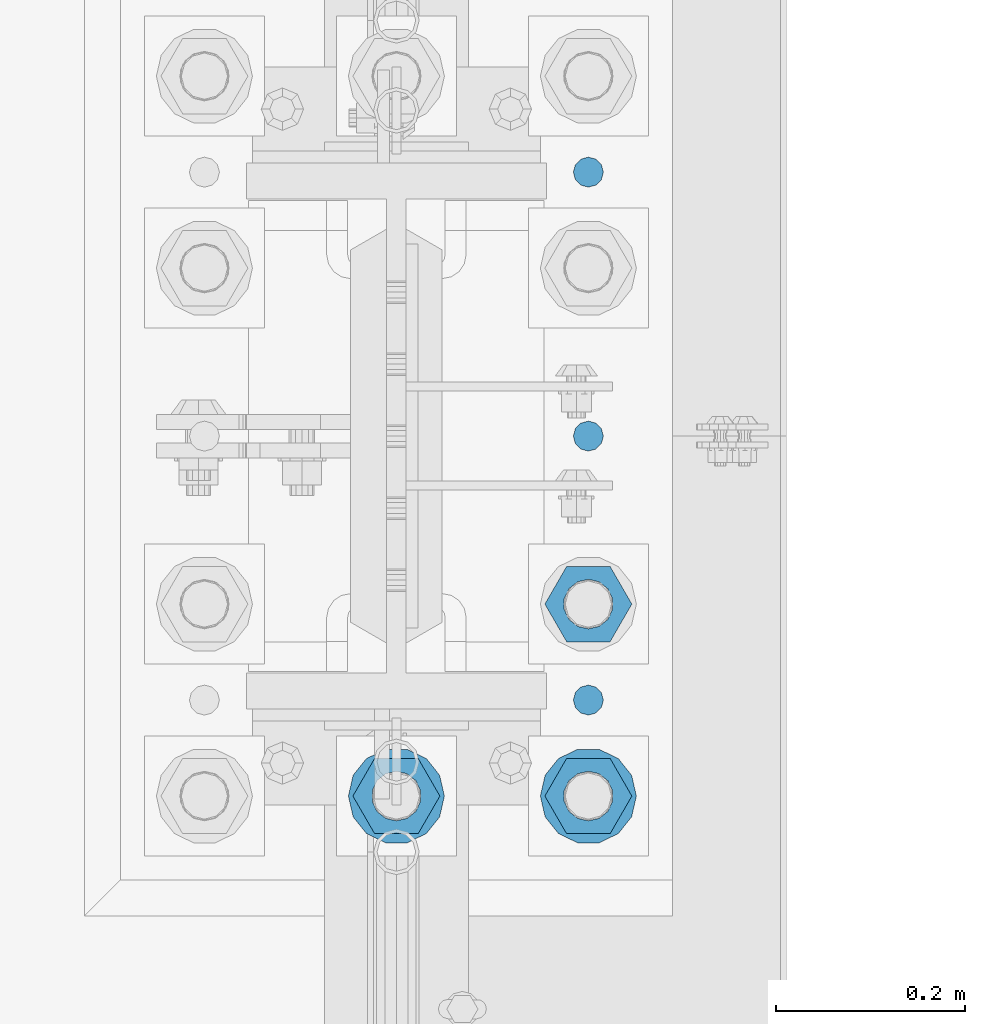
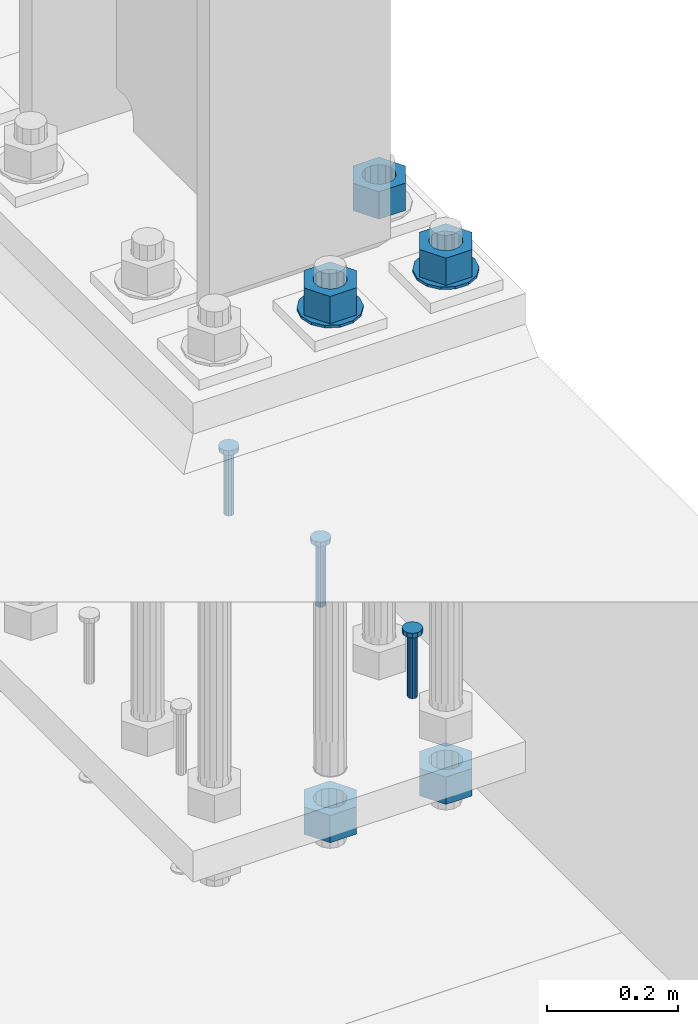
# One storey, part 842 of 1876: 10 columns, 1 element without a shape of its own.
"""IFC2X3 building model written with IfcOpenShell, lengths in millimetres."""

from ifc_helpers import new_model, si_unit, frame, origin_with_axes, place, context, subcontext, project, spatial, faceted_brep, material, type_object, element, aggregate, save


model = new_model("IFC2X3")

# Units and contexts
model_context = context("Model", 3, precision=1e-05, world=origin_with_axes())
body_context = subcontext(model_context, "Body", "Model", "MODEL_VIEW")
ifc_project = project(units=[si_unit("LENGTHUNIT", "METRE", prefix="MILLI"), si_unit("AREAUNIT", "SQUARE_METRE"), si_unit("VOLUMEUNIT", "CUBIC_METRE"), si_unit("MASSUNIT", "GRAM", prefix="KILO"), si_unit("TIMEUNIT", "SECOND"), si_unit("PLANEANGLEUNIT", "RADIAN"), si_unit("SOLIDANGLEUNIT", "STERADIAN"), si_unit("THERMODYNAMICTEMPERATUREUNIT", "DEGREE_CELSIUS"), si_unit("LUMINOUSINTENSITYUNIT", "LUMEN")], contexts=[model_context])

# Site, building, storey
site_placement = place(None, origin_with_axes())
site = spatial("IfcSite", under=ifc_project, at=site_placement, CompositionType="ELEMENT")
building_placement = place(site_placement, origin_with_axes())
building = spatial("IfcBuilding", under=site, at=building_placement, Name="Undefined", CompositionType="ELEMENT")
storey_placement = place(building_placement, origin_with_axes())
storey = spatial("IfcBuildingStorey", under=building, at=storey_placement, Name="Undefined", CompositionType="ELEMENT", Elevation=0.0)

# Assembly, columns
assembly_placement = place(storey_placement, origin_with_axes())
assembly = element("IfcElementAssembly", 1, at=assembly_placement, inside=storey, Name="TEMPLATE", AssemblyPlace="NOTDEFINED", PredefinedType="RIGID_FRAME")
ifc_material_1 = material(Name="STEEL/F436")
column_type_1 = type_object("IfcColumnType", Name="2_WASHER", PredefinedType="NOTDEFINED")
column_1_placement = place(assembly_placement, frame((7620.0, 1143.0, 119.0625), z_axis=(0.0, -1.0, 0.0), x_axis=(0.0, 0.0, -1.0)))
column_1 = element("IfcColumn", 2, at=column_1_placement, type_object=column_type_1, material=ifc_material_1, Name="WASHER", ObjectType="2_WASHER", context=body_context, shape_type="Brep", body=[
    faceted_brep([(0.0, -50.7999992370605, 9.09494701772928e-13), (0.0, -45.7692178020588, -22.0412936161442), (4.7625, -45.7692178020588, -22.0412936161442), (4.7625, -50.7999992370605, 9.09494701772928e-13), (0.0, -31.6732814587394, -39.7170387128856), (4.7625, -31.6732814587394, -39.7170387128856), (0.0, -11.3040632752118, -49.5263371950259), (4.7625, -11.3040632752118, -49.5263371950259), (0.0, 11.30406327521, -49.5263371950264), (4.7625, 11.30406327521, -49.5263371950264), (0.0, 31.6732814587385, -39.7170387128867), (4.7625, 31.6732814587385, -39.7170387128867), (0.0, 45.7692178020579, -22.041293616146), (4.7625, 45.7692178020579, -22.041293616146), (0.0, 50.7999992370605, -9.09494701772928e-13), (4.7625, 50.7999992370605, -9.09494701772928e-13), (0.0, 45.7692178020588, 22.0412936161442), (4.7625, 45.7692178020588, 22.0412936161442), (0.0, 31.6732814587394, 39.7170387128856), (4.7625, 31.6732814587394, 39.7170387128856), (0.0, 11.3040632752118, 49.5263371950259), (4.7625, 11.3040632752118, 49.5263371950259), (0.0, -11.30406327521, 49.5263371950264), (4.7625, -11.30406327521, 49.5263371950264), (0.0, -31.6732814587385, 39.7170387128867), (4.7625, -31.6732814587385, 39.7170387128867), (0.0, -45.7692178020579, 22.041293616146), (4.7625, -45.7692178020579, 22.041293616146), (0.0, 0.0, 26.9869995117188), (0.0, 11.7093983825444, 24.3146012721213), (4.7625, 11.7093983825444, 24.3146012721213), (4.7625, 0.0, 26.9869995117188), (0.0, 21.0996520289491, 16.8262864224157), (4.7625, 21.0996520289491, 16.8262864224157), (0.0, 26.3108629296712, 6.00524193584533), (4.7625, 26.3108629296712, 6.00524193584533), (0.0, 26.3108629296712, -6.00524193584533), (4.7625, 26.3108629296712, -6.00524193584533), (0.0, 21.0996520289491, -16.8262864224157), (4.7625, 21.0996520289491, -16.8262864224157), (0.0, 11.7093983825444, -24.3146012721213), (4.7625, 11.7093983825444, -24.3146012721213), (0.0, 0.0, -26.9869995117188), (4.7625, 0.0, -26.9869995117188), (0.0, -11.7093983825444, -24.3146012721213), (4.7625, -11.7093983825444, -24.3146012721213), (0.0, -21.0996520289491, -16.8262864224157), (4.7625, -21.0996520289491, -16.8262864224157), (0.0, -26.3108629296712, -6.00524193584533), (4.7625, -26.3108629296712, -6.00524193584533), (0.0, -26.3108629296712, 6.00524193584533), (4.7625, -26.3108629296712, 6.00524193584533), (0.0, -21.0996520289491, 16.8262864224157), (4.7625, -21.0996520289491, 16.8262864224157), (0.0, -11.7093983825444, 24.3146012721213), (4.7625, -11.7093983825444, 24.3146012721213)], [[[0, 1, 2, 3]], [[1, 4, 5, 2]], [[4, 6, 7, 5]], [[6, 8, 9, 7]], [[8, 10, 11, 9]], [[10, 12, 13, 11]], [[12, 14, 15, 13]], [[14, 16, 17, 15]], [[16, 18, 19, 17]], [[18, 20, 21, 19]], [[20, 22, 23, 21]], [[22, 24, 25, 23]], [[24, 26, 27, 25]], [[26, 0, 3, 27]], [[28, 29, 30, 31]], [[29, 32, 33, 30]], [[32, 34, 35, 33]], [[34, 36, 37, 35]], [[36, 38, 39, 37]], [[38, 40, 41, 39]], [[40, 42, 43, 41]], [[42, 44, 45, 43]], [[44, 46, 47, 45]], [[46, 48, 49, 47]], [[48, 50, 51, 49]], [[50, 52, 53, 51]], [[52, 54, 55, 53]], [[54, 28, 31, 55]], [[5, 7, 9, 11, 13, 15, 17, 19, 21, 23, 25, 27, 3, 2], [33, 35, 37, 39, 41, 43, 45, 47, 49, 51, 53, 55, 31, 30]], [[26, 24, 22, 20, 18, 16, 14, 12, 10, 8, 6, 4, 1, 0], [54, 52, 50, 48, 46, 44, 42, 40, 38, 36, 34, 32, 29, 28]]]),
])
column_2_placement = place(assembly_placement, frame((7823.2, 1143.0, 119.0625), z_axis=(0.0, 1.0, 0.0), x_axis=(0.0, 0.0, -1.0)))
column_2 = element("IfcColumn", 3, at=column_2_placement, type_object=column_type_1, material=ifc_material_1, Name="WASHER", ObjectType="2_WASHER", context=body_context, shape_type="Brep", body=[
    faceted_brep([(0.0, -50.7999992370605, 9.09494701772928e-13), (0.0, -45.7692178020588, -22.0412936161442), (4.7625, -45.7692178020588, -22.0412936161442), (4.7625, -50.7999992370605, 9.09494701772928e-13), (0.0, -31.6732814587394, -39.7170387128856), (4.7625, -31.6732814587394, -39.7170387128856), (0.0, -11.3040632752118, -49.5263371950259), (4.7625, -11.3040632752118, -49.5263371950259), (0.0, 11.30406327521, -49.5263371950264), (4.7625, 11.30406327521, -49.5263371950264), (0.0, 31.6732814587385, -39.7170387128867), (4.7625, 31.6732814587385, -39.7170387128867), (0.0, 45.7692178020579, -22.041293616146), (4.7625, 45.7692178020579, -22.041293616146), (0.0, 50.7999992370605, -9.09494701772928e-13), (4.7625, 50.7999992370605, -9.09494701772928e-13), (0.0, 45.7692178020588, 22.0412936161442), (4.7625, 45.7692178020588, 22.0412936161442), (0.0, 31.6732814587394, 39.7170387128856), (4.7625, 31.6732814587394, 39.7170387128856), (0.0, 11.3040632752118, 49.5263371950259), (4.7625, 11.3040632752118, 49.5263371950259), (0.0, -11.30406327521, 49.5263371950264), (4.7625, -11.30406327521, 49.5263371950264), (0.0, -31.6732814587385, 39.7170387128867), (4.7625, -31.6732814587385, 39.7170387128867), (0.0, -45.7692178020579, 22.041293616146), (4.7625, -45.7692178020579, 22.041293616146), (0.0, 0.0, 26.9869995117188), (0.0, 11.7093983825444, 24.3146012721213), (4.7625, 11.7093983825444, 24.3146012721213), (4.7625, 0.0, 26.9869995117188), (0.0, 21.0996520289491, 16.8262864224157), (4.7625, 21.0996520289491, 16.8262864224157), (0.0, 26.3108629296712, 6.00524193584533), (4.7625, 26.3108629296712, 6.00524193584533), (0.0, 26.3108629296712, -6.00524193584533), (4.7625, 26.3108629296712, -6.00524193584533), (0.0, 21.0996520289491, -16.8262864224157), (4.7625, 21.0996520289491, -16.8262864224157), (0.0, 11.7093983825444, -24.3146012721213), (4.7625, 11.7093983825444, -24.3146012721213), (0.0, 0.0, -26.9869995117188), (4.7625, 0.0, -26.9869995117188), (0.0, -11.7093983825444, -24.3146012721213), (4.7625, -11.7093983825444, -24.3146012721213), (0.0, -21.0996520289491, -16.8262864224157), (4.7625, -21.0996520289491, -16.8262864224157), (0.0, -26.3108629296712, -6.00524193584533), (4.7625, -26.3108629296712, -6.00524193584533), (0.0, -26.3108629296712, 6.00524193584533), (4.7625, -26.3108629296712, 6.00524193584533), (0.0, -21.0996520289491, 16.8262864224157), (4.7625, -21.0996520289491, 16.8262864224157), (0.0, -11.7093983825444, 24.3146012721213), (4.7625, -11.7093983825444, 24.3146012721213)], [[[0, 1, 2, 3]], [[1, 4, 5, 2]], [[4, 6, 7, 5]], [[6, 8, 9, 7]], [[8, 10, 11, 9]], [[10, 12, 13, 11]], [[12, 14, 15, 13]], [[14, 16, 17, 15]], [[16, 18, 19, 17]], [[18, 20, 21, 19]], [[20, 22, 23, 21]], [[22, 24, 25, 23]], [[24, 26, 27, 25]], [[26, 0, 3, 27]], [[28, 29, 30, 31]], [[29, 32, 33, 30]], [[32, 34, 35, 33]], [[34, 36, 37, 35]], [[36, 38, 39, 37]], [[38, 40, 41, 39]], [[40, 42, 43, 41]], [[42, 44, 45, 43]], [[44, 46, 47, 45]], [[46, 48, 49, 47]], [[48, 50, 51, 49]], [[50, 52, 53, 51]], [[52, 54, 55, 53]], [[54, 28, 31, 55]], [[5, 7, 9, 11, 13, 15, 17, 19, 21, 23, 25, 27, 3, 2], [33, 35, 37, 39, 41, 43, 45, 47, 49, 51, 53, 55, 31, 30]], [[26, 24, 22, 20, 18, 16, 14, 12, 10, 8, 6, 4, 1, 0], [54, 52, 50, 48, 46, 44, 42, 40, 38, 36, 34, 32, 29, 28]]]),
])
ifc_material_2 = material(Name="STEEL/A108")
column_type_2 = type_object("IfcColumnType", Name="5/8-DIA_HEADED ANCHOR STUD", PredefinedType="NOTDEFINED")
column_3_placement = place(assembly_placement, frame((7823.2, 1803.4, -736.6), z_axis=(1.0, 0.0, 0.0), x_axis=(0.0, 0.0, 1.0)))
column_3 = element("IfcColumn", 4, at=column_3_placement, type_object=column_type_2, material=ifc_material_2, Name="HEADED ANCHOR STUD", ObjectType="5/8-DIA_HEADED ANCHOR STUD", context=body_context, shape_type="Brep", body=[
    faceted_brep([(0.0, -7.94000005722046, 0.0), (0.0, -6.86999988555908, -3.97000002861023), (116.84, -6.86999988555908, -3.97000002861023), (116.84, -7.94000005722046, 0.0), (0.0, -3.97000002861023, -6.86999988555908), (116.84, -3.97000002861023, -6.86999988555908), (0.0, 0.0, -7.94000005722046), (116.84, 0.0, -7.94000005722046), (0.0, 3.97000002861023, -6.86999988555908), (116.84, 3.97000002861023, -6.86999988555908), (0.0, 6.86999988555908, -3.97000002861023), (116.84, 6.86999988555908, -3.97000002861023), (0.0, 7.94000005722046, 0.0), (116.84, 7.94000005722046, 0.0), (0.0, 6.86999988555908, 3.97000002861023), (116.84, 6.86999988555908, 3.97000002861023), (0.0, 3.97000002861023, 6.86999988555908), (116.84, 3.97000002861023, 6.86999988555908), (0.0, 0.0, 7.94000005722046), (116.84, 0.0, 7.94000005722046), (0.0, -3.97000002861023, 6.86999988555908), (116.84, -3.97000002861023, 6.86999988555908), (0.0, -6.86999988555908, 3.97000002861023), (116.84, -6.86999988555908, 3.97000002861023), (118.11, -13.75, -7.94000005722046), (118.11, -15.8800001144409, 0.0), (118.11, -7.94000005722046, -13.75), (118.11, 0.0, -15.8800001144409), (118.11, 7.94000005722046, -13.75), (118.11, 13.75, -7.94000005722046), (118.11, 15.8800001144409, 0.0), (118.11, 13.75, 7.94000005722046), (118.11, 7.94000005722046, 13.75), (118.11, 0.0, 15.8800001144409), (118.11, -7.94000005722046, 13.75), (118.11, -13.75, 7.94000005722046), (127.0, -13.75, -7.94000005722046), (127.0, -15.8800001144409, 0.0), (127.0, -7.94000005722046, -13.75), (127.0, 0.0, -15.8800001144409), (127.0, 7.94000005722046, -13.75), (127.0, 13.75, -7.94000005722046), (127.0, 15.8800001144409, 0.0), (127.0, 13.75, 7.94000005722046), (127.0, 7.94000005722046, 13.75), (127.0, 0.0, 15.8800001144409), (127.0, -7.94000005722046, 13.75), (127.0, -13.75, 7.94000005722046)], [[[0, 1, 2, 3]], [[1, 4, 5, 2]], [[4, 6, 7, 5]], [[6, 8, 9, 7]], [[8, 10, 11, 9]], [[10, 12, 13, 11]], [[12, 14, 15, 13]], [[14, 16, 17, 15]], [[16, 18, 19, 17]], [[18, 20, 21, 19]], [[20, 22, 23, 21]], [[22, 0, 3, 23]], [[22, 20, 18, 16, 14, 12, 10, 8, 6, 4, 1, 0]], [[3, 2, 24, 25]], [[2, 5, 26, 24]], [[5, 7, 27, 26]], [[7, 9, 28, 27]], [[9, 11, 29, 28]], [[11, 13, 30, 29]], [[13, 15, 31, 30]], [[15, 17, 32, 31]], [[17, 19, 33, 32]], [[19, 21, 34, 33]], [[21, 23, 35, 34]], [[23, 3, 25, 35]], [[25, 24, 36, 37]], [[24, 26, 38, 36]], [[26, 27, 39, 38]], [[27, 28, 40, 39]], [[28, 29, 41, 40]], [[29, 30, 42, 41]], [[30, 31, 43, 42]], [[31, 32, 44, 43]], [[32, 33, 45, 44]], [[33, 34, 46, 45]], [[34, 35, 47, 46]], [[35, 25, 37, 47]], [[38, 39, 40, 41, 42, 43, 44, 45, 46, 47, 37, 36]]]),
])
column_4_placement = place(assembly_placement, frame((7823.2, 1244.6, -736.6), z_axis=(1.0, 0.0, 0.0), x_axis=(0.0, 0.0, 1.0)))
column_4 = element("IfcColumn", 5, at=column_4_placement, type_object=column_type_2, material=ifc_material_2, Name="HEADED ANCHOR STUD", ObjectType="5/8-DIA_HEADED ANCHOR STUD", context=body_context, shape_type="Brep", body=[
    faceted_brep([(0.0, -7.94000005722046, 0.0), (0.0, -6.86999988555908, -3.97000002861023), (116.84, -6.86999988555908, -3.97000002861023), (116.84, -7.94000005722046, 0.0), (0.0, -3.97000002861023, -6.86999988555908), (116.84, -3.97000002861023, -6.86999988555908), (0.0, 0.0, -7.94000005722046), (116.84, 0.0, -7.94000005722046), (0.0, 3.97000002861023, -6.86999988555908), (116.84, 3.97000002861023, -6.86999988555908), (0.0, 6.86999988555908, -3.97000002861023), (116.84, 6.86999988555908, -3.97000002861023), (0.0, 7.94000005722046, 0.0), (116.84, 7.94000005722046, 0.0), (0.0, 6.86999988555908, 3.97000002861023), (116.84, 6.86999988555908, 3.97000002861023), (0.0, 3.97000002861023, 6.86999988555908), (116.84, 3.97000002861023, 6.86999988555908), (0.0, 0.0, 7.94000005722046), (116.84, 0.0, 7.94000005722046), (0.0, -3.97000002861023, 6.86999988555908), (116.84, -3.97000002861023, 6.86999988555908), (0.0, -6.86999988555908, 3.97000002861023), (116.84, -6.86999988555908, 3.97000002861023), (118.11, -13.75, -7.94000005722046), (118.11, -15.8800001144409, 0.0), (118.11, -7.94000005722046, -13.75), (118.11, 0.0, -15.8800001144409), (118.11, 7.94000005722046, -13.75), (118.11, 13.75, -7.94000005722046), (118.11, 15.8800001144409, 0.0), (118.11, 13.75, 7.94000005722046), (118.11, 7.94000005722046, 13.75), (118.11, 0.0, 15.8800001144409), (118.11, -7.94000005722046, 13.75), (118.11, -13.75, 7.94000005722046), (127.0, -13.75, -7.94000005722046), (127.0, -15.8800001144409, 0.0), (127.0, -7.94000005722046, -13.75), (127.0, 0.0, -15.8800001144409), (127.0, 7.94000005722046, -13.75), (127.0, 13.75, -7.94000005722046), (127.0, 15.8800001144409, 0.0), (127.0, 13.75, 7.94000005722046), (127.0, 7.94000005722046, 13.75), (127.0, 0.0, 15.8800001144409), (127.0, -7.94000005722046, 13.75), (127.0, -13.75, 7.94000005722046)], [[[0, 1, 2, 3]], [[1, 4, 5, 2]], [[4, 6, 7, 5]], [[6, 8, 9, 7]], [[8, 10, 11, 9]], [[10, 12, 13, 11]], [[12, 14, 15, 13]], [[14, 16, 17, 15]], [[16, 18, 19, 17]], [[18, 20, 21, 19]], [[20, 22, 23, 21]], [[22, 0, 3, 23]], [[22, 20, 18, 16, 14, 12, 10, 8, 6, 4, 1, 0]], [[3, 2, 24, 25]], [[2, 5, 26, 24]], [[5, 7, 27, 26]], [[7, 9, 28, 27]], [[9, 11, 29, 28]], [[11, 13, 30, 29]], [[13, 15, 31, 30]], [[15, 17, 32, 31]], [[17, 19, 33, 32]], [[19, 21, 34, 33]], [[21, 23, 35, 34]], [[23, 3, 25, 35]], [[25, 24, 36, 37]], [[24, 26, 38, 36]], [[26, 27, 39, 38]], [[27, 28, 40, 39]], [[28, 29, 41, 40]], [[29, 30, 42, 41]], [[30, 31, 43, 42]], [[31, 32, 44, 43]], [[32, 33, 45, 44]], [[33, 34, 46, 45]], [[34, 35, 47, 46]], [[35, 25, 37, 47]], [[38, 39, 40, 41, 42, 43, 44, 45, 46, 47, 37, 36]]]),
])
column_5_placement = place(assembly_placement, frame((7823.2, 1524.0, -736.6), z_axis=(1.0, 0.0, 0.0), x_axis=(0.0, 0.0, 1.0)))
column_5 = element("IfcColumn", 6, at=column_5_placement, type_object=column_type_2, material=ifc_material_2, Name="HEADED ANCHOR STUD", ObjectType="5/8-DIA_HEADED ANCHOR STUD", context=body_context, shape_type="Brep", body=[
    faceted_brep([(0.0, -7.94000005722046, 0.0), (0.0, -6.86999988555908, -3.97000002861023), (116.84, -6.86999988555908, -3.97000002861023), (116.84, -7.94000005722046, 0.0), (0.0, -3.97000002861023, -6.86999988555908), (116.84, -3.97000002861023, -6.86999988555908), (0.0, 0.0, -7.94000005722046), (116.84, 0.0, -7.94000005722046), (0.0, 3.97000002861023, -6.86999988555908), (116.84, 3.97000002861023, -6.86999988555908), (0.0, 6.86999988555908, -3.97000002861023), (116.84, 6.86999988555908, -3.97000002861023), (0.0, 7.94000005722046, 0.0), (116.84, 7.94000005722046, 0.0), (0.0, 6.86999988555908, 3.97000002861023), (116.84, 6.86999988555908, 3.97000002861023), (0.0, 3.97000002861023, 6.86999988555908), (116.84, 3.97000002861023, 6.86999988555908), (0.0, 0.0, 7.94000005722046), (116.84, 0.0, 7.94000005722046), (0.0, -3.97000002861023, 6.86999988555908), (116.84, -3.97000002861023, 6.86999988555908), (0.0, -6.86999988555908, 3.97000002861023), (116.84, -6.86999988555908, 3.97000002861023), (118.11, -13.75, -7.94000005722046), (118.11, -15.8800001144409, 0.0), (118.11, -7.94000005722046, -13.75), (118.11, 0.0, -15.8800001144409), (118.11, 7.94000005722046, -13.75), (118.11, 13.75, -7.94000005722046), (118.11, 15.8800001144409, 0.0), (118.11, 13.75, 7.94000005722046), (118.11, 7.94000005722046, 13.75), (118.11, 0.0, 15.8800001144409), (118.11, -7.94000005722046, 13.75), (118.11, -13.75, 7.94000005722046), (127.0, -13.75, -7.94000005722046), (127.0, -15.8800001144409, 0.0), (127.0, -7.94000005722046, -13.75), (127.0, 0.0, -15.8800001144409), (127.0, 7.94000005722046, -13.75), (127.0, 13.75, -7.94000005722046), (127.0, 15.8800001144409, 0.0), (127.0, 13.75, 7.94000005722046), (127.0, 7.94000005722046, 13.75), (127.0, 0.0, 15.8800001144409), (127.0, -7.94000005722046, 13.75), (127.0, -13.75, 7.94000005722046)], [[[0, 1, 2, 3]], [[1, 4, 5, 2]], [[4, 6, 7, 5]], [[6, 8, 9, 7]], [[8, 10, 11, 9]], [[10, 12, 13, 11]], [[12, 14, 15, 13]], [[14, 16, 17, 15]], [[16, 18, 19, 17]], [[18, 20, 21, 19]], [[20, 22, 23, 21]], [[22, 0, 3, 23]], [[22, 20, 18, 16, 14, 12, 10, 8, 6, 4, 1, 0]], [[3, 2, 24, 25]], [[2, 5, 26, 24]], [[5, 7, 27, 26]], [[7, 9, 28, 27]], [[9, 11, 29, 28]], [[11, 13, 30, 29]], [[13, 15, 31, 30]], [[15, 17, 32, 31]], [[17, 19, 33, 32]], [[19, 21, 34, 33]], [[21, 23, 35, 34]], [[23, 3, 25, 35]], [[25, 24, 36, 37]], [[24, 26, 38, 36]], [[26, 27, 39, 38]], [[27, 28, 40, 39]], [[28, 29, 41, 40]], [[29, 30, 42, 41]], [[30, 31, 43, 42]], [[31, 32, 44, 43]], [[32, 33, 45, 44]], [[33, 34, 46, 45]], [[34, 35, 47, 46]], [[35, 25, 37, 47]], [[38, 39, 40, 41, 42, 43, 44, 45, 46, 47, 37, 36]]]),
])
ifc_material_3 = material(Name="STEEL/A563")
column_type_3 = type_object("IfcColumnType", Name="2_HEAVY_HEX_NUT", PredefinedType="NOTDEFINED")
column_6_placement = place(assembly_placement, frame((7620.0, 1143.0, 169.8625), z_axis=(0.0, -1.0, 0.0), x_axis=(0.0, 0.0, -1.0)))
column_6 = element("IfcColumn", 7, at=column_6_placement, type_object=column_type_3, material=ifc_material_3, Name="NUT", ObjectType="2_HEAVY_HEX_NUT", context=body_context, shape_type="Brep", body=[
    faceted_brep([(0.0, -46.0369987487793, 9.09494701772928e-13), (0.0, -23.0184993743896, -39.869213104248), (50.8, -23.0184993743896, -39.869213104248), (50.8, -46.0369987487793, 9.09494701772928e-13), (0.0, 23.0184993743896, -39.869213104248), (50.8, 23.0184993743896, -39.869213104248), (0.0, 46.0369987487793, -9.09494701772928e-13), (50.8, 46.0369987487793, -9.09494701772928e-13), (0.0, 23.0184993743896, 39.869213104248), (50.8, 23.0184993743896, 39.869213104248), (0.0, -23.0184993743896, 39.869213104248), (50.8, -23.0184993743896, 39.869213104248), (0.0, 0.0, 26.1940002441406), (0.0, 11.3650617044514, 23.5999013092769), (50.8, 11.3650617044513, 23.5999013092771), (50.8, 0.0, 26.1940002441406), (0.0, 20.4791109456437, 16.3316083006703), (50.8, 20.4791109456439, 16.3316083006703), (0.0, 25.5370200498346, 5.82867859874477), (50.8, 25.5370200498343, 5.82867859874455), (0.0, 25.5370200498346, -5.82867859874477), (50.8, 25.5370200498343, -5.82867859874455), (0.0, 20.4791109456437, -16.3316083006703), (50.8, 20.4791109456439, -16.3316083006703), (0.0, 11.3650617044514, -23.5999013092769), (50.8, 11.3650617044514, -23.5999013092771), (0.0, 0.0, -26.1940002441406), (50.8, 0.0, -26.1940002441406), (0.0, -11.3650617044514, -23.5999013092769), (50.8, -11.3650617044513, -23.5999013092771), (0.0, -20.4791109456437, -16.3316083006703), (50.8, -20.4791109456439, -16.3316083006703), (0.0, -25.5370200498346, -5.82867859874477), (50.8, -25.5370200498343, -5.82867859874455), (0.0, -25.5370200498346, 5.82867859874477), (50.8, -25.5370200498343, 5.82867859874455), (0.0, -20.4791109456437, 16.3316083006703), (50.8, -20.4791109456439, 16.3316083006703), (0.0, -11.3650617044514, 23.5999013092769), (50.8, -11.3650617044514, 23.5999013092771)], [[[0, 1, 2, 3]], [[1, 4, 5, 2]], [[4, 6, 7, 5]], [[6, 8, 9, 7]], [[8, 10, 11, 9]], [[10, 0, 3, 11]], [[12, 13, 14, 15]], [[13, 16, 17, 14]], [[16, 18, 19, 17]], [[18, 20, 21, 19]], [[20, 22, 23, 21]], [[22, 24, 25, 23]], [[24, 26, 27, 25]], [[26, 28, 29, 27]], [[28, 30, 31, 29]], [[30, 32, 33, 31]], [[32, 34, 35, 33]], [[34, 36, 37, 35]], [[36, 38, 39, 37]], [[38, 12, 15, 39]], [[5, 7, 9, 11, 3, 2], [17, 19, 21, 23, 25, 27, 29, 31, 33, 35, 37, 39, 15, 14]], [[10, 8, 6, 4, 1, 0], [38, 36, 34, 32, 30, 28, 26, 24, 22, 20, 18, 16, 13, 12]]]),
])
column_7_placement = place(assembly_placement, frame((7620.0, 1143.0, -793.75), z_axis=(0.0, -1.0, 0.0), x_axis=(0.0, 0.0, -1.0)))
column_7 = element("IfcColumn", 8, at=column_7_placement, type_object=column_type_3, material=ifc_material_3, Name="NUT", ObjectType="2_HEAVY_HEX_NUT", context=body_context, shape_type="Brep", body=[
    faceted_brep([(0.0, -46.0369987487793, 9.09494701772928e-13), (0.0, -23.0184993743896, -39.869213104248), (50.8, -23.0184993743896, -39.869213104248), (50.8, -46.0369987487793, 9.09494701772928e-13), (0.0, 23.0184993743896, -39.869213104248), (50.8, 23.0184993743896, -39.869213104248), (0.0, 46.0369987487793, -9.09494701772928e-13), (50.8, 46.0369987487793, -9.09494701772928e-13), (0.0, 23.0184993743896, 39.869213104248), (50.8, 23.0184993743896, 39.869213104248), (0.0, -23.0184993743896, 39.869213104248), (50.8, -23.0184993743896, 39.869213104248), (0.0, 0.0, 26.1940002441406), (0.0, 11.3650617044514, 23.5999013092769), (50.8, 11.3650617044513, 23.5999013092771), (50.8, 0.0, 26.1940002441406), (0.0, 20.4791109456437, 16.3316083006703), (50.8, 20.4791109456439, 16.3316083006703), (0.0, 25.5370200498346, 5.82867859874477), (50.8, 25.5370200498343, 5.82867859874455), (0.0, 25.5370200498346, -5.82867859874477), (50.8, 25.5370200498343, -5.82867859874455), (0.0, 20.4791109456437, -16.3316083006703), (50.8, 20.4791109456439, -16.3316083006703), (0.0, 11.3650617044514, -23.5999013092769), (50.8, 11.3650617044514, -23.5999013092771), (0.0, 0.0, -26.1940002441406), (50.8, 0.0, -26.1940002441406), (0.0, -11.3650617044514, -23.5999013092769), (50.8, -11.3650617044513, -23.5999013092771), (0.0, -20.4791109456437, -16.3316083006703), (50.8, -20.4791109456439, -16.3316083006703), (0.0, -25.5370200498346, -5.82867859874477), (50.8, -25.5370200498343, -5.82867859874455), (0.0, -25.5370200498346, 5.82867859874477), (50.8, -25.5370200498343, 5.82867859874455), (0.0, -20.4791109456437, 16.3316083006703), (50.8, -20.4791109456439, 16.3316083006703), (0.0, -11.3650617044514, 23.5999013092769), (50.8, -11.3650617044514, 23.5999013092771)], [[[0, 1, 2, 3]], [[1, 4, 5, 2]], [[4, 6, 7, 5]], [[6, 8, 9, 7]], [[8, 10, 11, 9]], [[10, 0, 3, 11]], [[12, 13, 14, 15]], [[13, 16, 17, 14]], [[16, 18, 19, 17]], [[18, 20, 21, 19]], [[20, 22, 23, 21]], [[22, 24, 25, 23]], [[24, 26, 27, 25]], [[26, 28, 29, 27]], [[28, 30, 31, 29]], [[30, 32, 33, 31]], [[32, 34, 35, 33]], [[34, 36, 37, 35]], [[36, 38, 39, 37]], [[38, 12, 15, 39]], [[5, 7, 9, 11, 3, 2], [17, 19, 21, 23, 25, 27, 29, 31, 33, 35, 37, 39, 15, 14]], [[10, 8, 6, 4, 1, 0], [38, 36, 34, 32, 30, 28, 26, 24, 22, 20, 18, 16, 13, 12]]]),
])
column_8_placement = place(assembly_placement, frame((7823.2, 1143.0, 169.8625), z_axis=(0.0, 1.0, 0.0), x_axis=(0.0, 0.0, -1.0)))
column_8 = element("IfcColumn", 9, at=column_8_placement, type_object=column_type_3, material=ifc_material_3, Name="NUT", ObjectType="2_HEAVY_HEX_NUT", context=body_context, shape_type="Brep", body=[
    faceted_brep([(0.0, -46.0369987487793, 9.09494701772928e-13), (0.0, -23.0184993743896, -39.869213104248), (50.8, -23.0184993743896, -39.869213104248), (50.8, -46.0369987487793, 9.09494701772928e-13), (0.0, 23.0184993743896, -39.869213104248), (50.8, 23.0184993743896, -39.869213104248), (0.0, 46.0369987487793, -9.09494701772928e-13), (50.8, 46.0369987487793, -9.09494701772928e-13), (0.0, 23.0184993743896, 39.869213104248), (50.8, 23.0184993743896, 39.869213104248), (0.0, -23.0184993743896, 39.869213104248), (50.8, -23.0184993743896, 39.869213104248), (0.0, 0.0, 26.1940002441406), (0.0, 11.3650617044514, 23.5999013092769), (50.8, 11.3650617044513, 23.5999013092771), (50.8, 0.0, 26.1940002441406), (0.0, 20.4791109456437, 16.3316083006703), (50.8, 20.4791109456439, 16.3316083006703), (0.0, 25.5370200498346, 5.82867859874477), (50.8, 25.5370200498343, 5.82867859874455), (0.0, 25.5370200498346, -5.82867859874477), (50.8, 25.5370200498343, -5.82867859874455), (0.0, 20.4791109456437, -16.3316083006703), (50.8, 20.4791109456439, -16.3316083006703), (0.0, 11.3650617044514, -23.5999013092769), (50.8, 11.3650617044514, -23.5999013092771), (0.0, 0.0, -26.1940002441406), (50.8, 0.0, -26.1940002441406), (0.0, -11.3650617044514, -23.5999013092769), (50.8, -11.3650617044513, -23.5999013092771), (0.0, -20.4791109456437, -16.3316083006703), (50.8, -20.4791109456439, -16.3316083006703), (0.0, -25.5370200498346, -5.82867859874477), (50.8, -25.5370200498343, -5.82867859874455), (0.0, -25.5370200498346, 5.82867859874477), (50.8, -25.5370200498343, 5.82867859874455), (0.0, -20.4791109456437, 16.3316083006703), (50.8, -20.4791109456439, 16.3316083006703), (0.0, -11.3650617044514, 23.5999013092769), (50.8, -11.3650617044514, 23.5999013092771)], [[[0, 1, 2, 3]], [[1, 4, 5, 2]], [[4, 6, 7, 5]], [[6, 8, 9, 7]], [[8, 10, 11, 9]], [[10, 0, 3, 11]], [[12, 13, 14, 15]], [[13, 16, 17, 14]], [[16, 18, 19, 17]], [[18, 20, 21, 19]], [[20, 22, 23, 21]], [[22, 24, 25, 23]], [[24, 26, 27, 25]], [[26, 28, 29, 27]], [[28, 30, 31, 29]], [[30, 32, 33, 31]], [[32, 34, 35, 33]], [[34, 36, 37, 35]], [[36, 38, 39, 37]], [[38, 12, 15, 39]], [[5, 7, 9, 11, 3, 2], [17, 19, 21, 23, 25, 27, 29, 31, 33, 35, 37, 39, 15, 14]], [[10, 8, 6, 4, 1, 0], [38, 36, 34, 32, 30, 28, 26, 24, 22, 20, 18, 16, 13, 12]]]),
])
column_9_placement = place(assembly_placement, frame((7823.2, 1143.0, -793.75), z_axis=(0.0, 1.0, 0.0), x_axis=(0.0, 0.0, -1.0)))
column_9 = element("IfcColumn", 10, at=column_9_placement, type_object=column_type_3, material=ifc_material_3, Name="NUT", ObjectType="2_HEAVY_HEX_NUT", context=body_context, shape_type="Brep", body=[
    faceted_brep([(0.0, -46.0369987487793, 9.09494701772928e-13), (0.0, -23.0184993743896, -39.869213104248), (50.8, -23.0184993743896, -39.869213104248), (50.8, -46.0369987487793, 9.09494701772928e-13), (0.0, 23.0184993743896, -39.869213104248), (50.8, 23.0184993743896, -39.869213104248), (0.0, 46.0369987487793, -9.09494701772928e-13), (50.8, 46.0369987487793, -9.09494701772928e-13), (0.0, 23.0184993743896, 39.869213104248), (50.8, 23.0184993743896, 39.869213104248), (0.0, -23.0184993743896, 39.869213104248), (50.8, -23.0184993743896, 39.869213104248), (0.0, 0.0, 26.1940002441406), (0.0, 11.3650617044514, 23.5999013092769), (50.8, 11.3650617044513, 23.5999013092771), (50.8, 0.0, 26.1940002441406), (0.0, 20.4791109456437, 16.3316083006703), (50.8, 20.4791109456439, 16.3316083006703), (0.0, 25.5370200498346, 5.82867859874477), (50.8, 25.5370200498343, 5.82867859874455), (0.0, 25.5370200498346, -5.82867859874477), (50.8, 25.5370200498343, -5.82867859874455), (0.0, 20.4791109456437, -16.3316083006703), (50.8, 20.4791109456439, -16.3316083006703), (0.0, 11.3650617044514, -23.5999013092769), (50.8, 11.3650617044514, -23.5999013092771), (0.0, 0.0, -26.1940002441406), (50.8, 0.0, -26.1940002441406), (0.0, -11.3650617044514, -23.5999013092769), (50.8, -11.3650617044513, -23.5999013092771), (0.0, -20.4791109456437, -16.3316083006703), (50.8, -20.4791109456439, -16.3316083006703), (0.0, -25.5370200498346, -5.82867859874477), (50.8, -25.5370200498343, -5.82867859874455), (0.0, -25.5370200498346, 5.82867859874477), (50.8, -25.5370200498343, 5.82867859874455), (0.0, -20.4791109456437, 16.3316083006703), (50.8, -20.4791109456439, 16.3316083006703), (0.0, -11.3650617044514, 23.5999013092769), (50.8, -11.3650617044514, 23.5999013092771)], [[[0, 1, 2, 3]], [[1, 4, 5, 2]], [[4, 6, 7, 5]], [[6, 8, 9, 7]], [[8, 10, 11, 9]], [[10, 0, 3, 11]], [[12, 13, 14, 15]], [[13, 16, 17, 14]], [[16, 18, 19, 17]], [[18, 20, 21, 19]], [[20, 22, 23, 21]], [[22, 24, 25, 23]], [[24, 26, 27, 25]], [[26, 28, 29, 27]], [[28, 30, 31, 29]], [[30, 32, 33, 31]], [[32, 34, 35, 33]], [[34, 36, 37, 35]], [[36, 38, 39, 37]], [[38, 12, 15, 39]], [[5, 7, 9, 11, 3, 2], [17, 19, 21, 23, 25, 27, 29, 31, 33, 35, 37, 39, 15, 14]], [[10, 8, 6, 4, 1, 0], [38, 36, 34, 32, 30, 28, 26, 24, 22, 20, 18, 16, 13, 12]]]),
])
column_10_placement = place(assembly_placement, frame((7823.2, 1346.2, 169.8625), z_axis=(0.0, 1.0, 0.0), x_axis=(0.0, 0.0, -1.0)))
column_10 = element("IfcColumn", 11, at=column_10_placement, type_object=column_type_3, material=ifc_material_3, Name="NUT", ObjectType="2_HEAVY_HEX_NUT", context=body_context, shape_type="Brep", body=[
    faceted_brep([(0.0, -46.0369987487793, 9.09494701772928e-13), (0.0, -23.0184993743896, -39.869213104248), (50.8, -23.0184993743896, -39.869213104248), (50.8, -46.0369987487793, 9.09494701772928e-13), (0.0, 23.0184993743896, -39.869213104248), (50.8, 23.0184993743896, -39.869213104248), (0.0, 46.0369987487793, -9.09494701772928e-13), (50.8, 46.0369987487793, -9.09494701772928e-13), (0.0, 23.0184993743896, 39.869213104248), (50.8, 23.0184993743896, 39.869213104248), (0.0, -23.0184993743896, 39.869213104248), (50.8, -23.0184993743896, 39.869213104248), (0.0, 0.0, 26.1940002441406), (0.0, 11.3650617044514, 23.5999013092769), (50.8, 11.3650617044513, 23.5999013092771), (50.8, 0.0, 26.1940002441406), (0.0, 20.4791109456437, 16.3316083006703), (50.8, 20.4791109456439, 16.3316083006703), (0.0, 25.5370200498346, 5.82867859874477), (50.8, 25.5370200498343, 5.82867859874455), (0.0, 25.5370200498346, -5.82867859874477), (50.8, 25.5370200498343, -5.82867859874455), (0.0, 20.4791109456437, -16.3316083006703), (50.8, 20.4791109456439, -16.3316083006703), (0.0, 11.3650617044514, -23.5999013092769), (50.8, 11.3650617044514, -23.5999013092771), (0.0, 0.0, -26.1940002441406), (50.8, 0.0, -26.1940002441406), (0.0, -11.3650617044514, -23.5999013092769), (50.8, -11.3650617044513, -23.5999013092771), (0.0, -20.4791109456437, -16.3316083006703), (50.8, -20.4791109456439, -16.3316083006703), (0.0, -25.5370200498346, -5.82867859874477), (50.8, -25.5370200498343, -5.82867859874455), (0.0, -25.5370200498346, 5.82867859874477), (50.8, -25.5370200498343, 5.82867859874455), (0.0, -20.4791109456437, 16.3316083006703), (50.8, -20.4791109456439, 16.3316083006703), (0.0, -11.3650617044514, 23.5999013092769), (50.8, -11.3650617044514, 23.5999013092771)], [[[0, 1, 2, 3]], [[1, 4, 5, 2]], [[4, 6, 7, 5]], [[6, 8, 9, 7]], [[8, 10, 11, 9]], [[10, 0, 3, 11]], [[12, 13, 14, 15]], [[13, 16, 17, 14]], [[16, 18, 19, 17]], [[18, 20, 21, 19]], [[20, 22, 23, 21]], [[22, 24, 25, 23]], [[24, 26, 27, 25]], [[26, 28, 29, 27]], [[28, 30, 31, 29]], [[30, 32, 33, 31]], [[32, 34, 35, 33]], [[34, 36, 37, 35]], [[36, 38, 39, 37]], [[38, 12, 15, 39]], [[5, 7, 9, 11, 3, 2], [17, 19, 21, 23, 25, 27, 29, 31, 33, 35, 37, 39, 15, 14]], [[10, 8, 6, 4, 1, 0], [38, 36, 34, 32, 30, 28, 26, 24, 22, 20, 18, 16, 13, 12]]]),
])
aggregate(assembly, [column_3, column_4, column_5, column_6, column_1, column_7, column_8, column_2, column_9, column_10])

save(model, "model.ifc")
